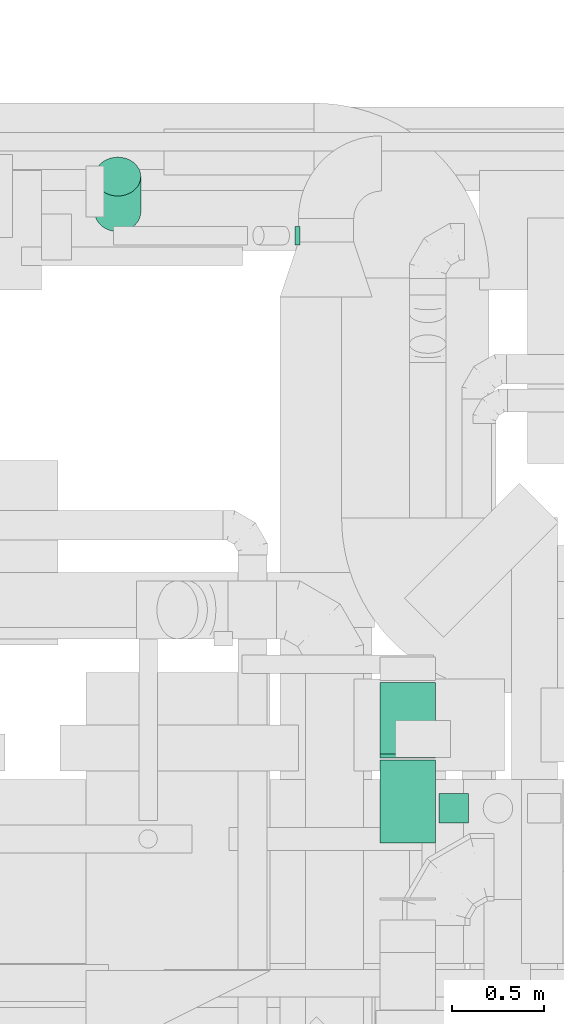
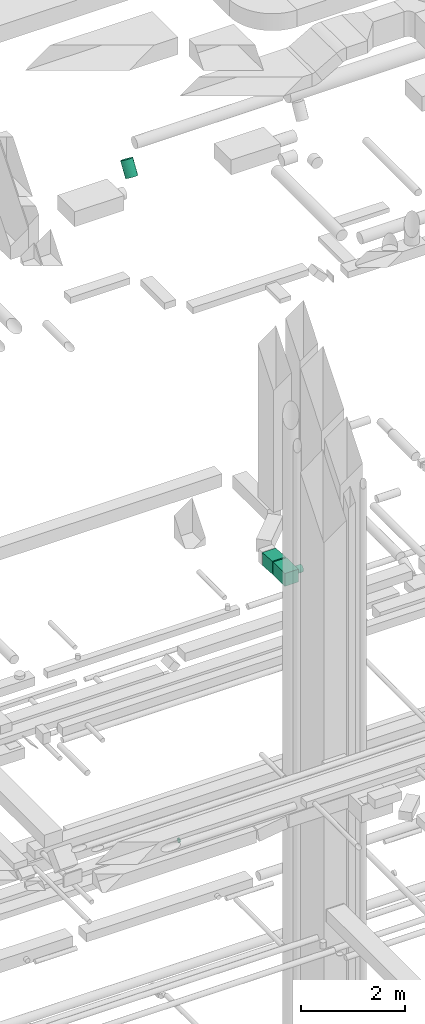
# One storey, part 278 of 337: 5 flow segments.
"""IFC2X3 building model written with IfcOpenShell, lengths in millimetres."""

from ifc_helpers import new_model, entity, si_unit, converted_unit, derived_unit, direction, frame, frame_2d, origin, origin_2d_with_axis, place, context, subcontext, project, spatial, rectangle, circle, extrude, type_object, element, save


model = new_model("IFC2X3")

# Units and contexts
model_context = context("Model", 3, precision=0.01, world=origin(), true_north=direction((6.12303176911189e-17, 1.0)))
body_context = subcontext(model_context, "Body", "Model", "MODEL_VIEW")
ifc_project = project(units=[si_unit("LENGTHUNIT", "METRE", prefix="MILLI"), si_unit("AREAUNIT", "SQUARE_METRE"), si_unit("VOLUMEUNIT", "CUBIC_METRE"), converted_unit("PLANEANGLEUNIT", "DEGREE", entity("IfcRatioMeasure", 0.0174532925199433), si_unit("PLANEANGLEUNIT", "RADIAN"), dimensions=[0, 0, 0, 0, 0, 0, 0]), si_unit("MASSUNIT", "GRAM", prefix="KILO"), derived_unit("MASSDENSITYUNIT", [(si_unit("MASSUNIT", "GRAM", prefix="KILO"), 1), (si_unit("LENGTHUNIT", "METRE"), -3)]), derived_unit("MOMENTOFINERTIAUNIT", [(si_unit("LENGTHUNIT", "METRE"), 4)]), si_unit("TIMEUNIT", "SECOND"), si_unit("FREQUENCYUNIT", "HERTZ"), si_unit("THERMODYNAMICTEMPERATUREUNIT", "DEGREE_CELSIUS"), derived_unit("THERMALTRANSMITTANCEUNIT", [(si_unit("MASSUNIT", "GRAM", prefix="KILO"), 1), (si_unit("THERMODYNAMICTEMPERATUREUNIT", "KELVIN"), -1), (si_unit("TIMEUNIT", "SECOND"), -3)]), derived_unit("VOLUMETRICFLOWRATEUNIT", [(si_unit("LENGTHUNIT", "METRE"), 3), (si_unit("TIMEUNIT", "SECOND"), -1)]), derived_unit("MASSFLOWRATEUNIT", [(si_unit("MASSUNIT", "GRAM", prefix="KILO"), 1), (si_unit("TIMEUNIT", "SECOND"), -1)]), derived_unit("ROTATIONALFREQUENCYUNIT", [(si_unit("TIMEUNIT", "SECOND"), -1)]), si_unit("ELECTRICCURRENTUNIT", "AMPERE"), si_unit("ELECTRICVOLTAGEUNIT", "VOLT"), si_unit("POWERUNIT", "WATT"), si_unit("FORCEUNIT", "NEWTON", prefix="KILO"), si_unit("ILLUMINANCEUNIT", "LUX"), si_unit("LUMINOUSFLUXUNIT", "LUMEN"), si_unit("LUMINOUSINTENSITYUNIT", "CANDELA"), derived_unit("USERDEFINED", [(si_unit("MASSUNIT", "GRAM", prefix="KILO"), -1), (si_unit("LENGTHUNIT", "METRE"), -2), (si_unit("TIMEUNIT", "SECOND"), 3), (si_unit("LUMINOUSFLUXUNIT", "LUMEN"), 1)]), derived_unit("LINEARVELOCITYUNIT", [(si_unit("LENGTHUNIT", "METRE"), 1), (si_unit("TIMEUNIT", "SECOND"), -1)]), si_unit("PRESSUREUNIT", "PASCAL"), derived_unit("USERDEFINED", [(si_unit("LENGTHUNIT", "METRE"), -2), (si_unit("MASSUNIT", "GRAM", prefix="KILO"), 1), (si_unit("TIMEUNIT", "SECOND"), -2)]), derived_unit("LINEARFORCEUNIT", [(si_unit("MASSUNIT", "GRAM", prefix="KILO"), 1), (si_unit("LENGTHUNIT", "METRE"), 1), (si_unit("TIMEUNIT", "SECOND"), -2), (si_unit("LENGTHUNIT", "METRE"), -1)]), derived_unit("PLANARFORCEUNIT", [(si_unit("MASSUNIT", "GRAM", prefix="KILO"), 1), (si_unit("LENGTHUNIT", "METRE"), 1), (si_unit("TIMEUNIT", "SECOND"), -2), (si_unit("LENGTHUNIT", "METRE"), -2)])], contexts=[model_context])

# Site, building, storey
site_placement = place(None, origin())
site = spatial("IfcSite", under=ifc_project, at=site_placement, CompositionType="ELEMENT")
building_placement = place(site_placement, origin())
building = spatial("IfcBuilding", under=site, at=building_placement, CompositionType="ELEMENT")
storey_placement = place(building_placement, origin())
storey = spatial("IfcBuildingStorey", under=building, at=storey_placement, CompositionType="ELEMENT", Elevation=0.0)

# Flow segments
duct_segment_type_1 = type_object("IfcDuctSegmentType", PredefinedType="NOTDEFINED")
flow_segment_1_placement = place(storey_placement, frame((46619.03, 16570.21, 19021.2)))
element("IfcFlowSegment", 1, at=flow_segment_1_placement, inside=storey, type_object=duct_segment_type_1, context=body_context, shape_type="SweptSolid", body=[
    extrude(rectangle(XDim=300.000000000002, YDim=389.27575588517, at=frame_2d((0.0, 0.0), x_axis=(0.0, 1.0))), frame((0.0, 205.06, 163.8), z_axis=(1.0, 0.0, 0.0), x_axis=(0.0, -0.997334975567425, 0.0729585259577274)), (0.0, 0.0, 1.0), 300.000000000001),
])
flow_segment_2_placement = place(storey_placement, frame((46619.03, 16110.23, 19050.0)))
element("IfcFlowSegment", 2, at=flow_segment_2_placement, inside=storey, type_object=duct_segment_type_1, context=body_context, shape_type="SweptSolid", body=[
    extrude(rectangle(XDim=449.041618929892, YDim=300.000000000001, at=origin_2d_with_axis()), frame((150.0, 224.52, 0.0), z_axis=(0.0, 0.0, 1.0), x_axis=(0.0, -1.0, 0.0)), (0.0, 0.0, 1.0), 300.000000000001),
])
duct_segment_type_2 = type_object("IfcDuctSegmentType", PredefinedType="NOTDEFINED")
flow_segment_3_placement = place(storey_placement, frame((46157.39, 19353.19, 11203.97)))
element("IfcFlowSegment", 3, at=flow_segment_3_placement, inside=storey, type_object=duct_segment_type_2, context=body_context, shape_type="SweptSolid", body=[
    extrude(circle(Radius=50.0, at=origin_2d_with_axis()), frame((0.0, 51.6, 51.6), z_axis=(1.0, 0.0, 0.0), x_axis=(0.0, -1.0, 0.0)), (0.0, 0.0, 1.0), 26.6347957254866),
])
flow_segment_4_placement = place(storey_placement, frame((46939.03, 16216.25, 19118.4)))
element("IfcFlowSegment", 4, at=flow_segment_4_placement, inside=storey, type_object=duct_segment_type_2, context=body_context, shape_type="SweptSolid", body=[
    extrude(circle(Radius=80.0, at=origin_2d_with_axis()), frame((0.0, 81.6, 81.6), z_axis=(1.0, 0.0, 0.0), x_axis=(0.0, 1.0, 0.0)), (0.0, 0.0, 1.0), 159.062500000026),
])
flow_segment_5_placement = place(storey_placement, frame((45069.11, 19424.89, 27017.25)))
element("IfcFlowSegment", 5, at=flow_segment_5_placement, inside=storey, type_object=duct_segment_type_2, context=body_context, shape_type="SweptSolid", body=[
    extrude(circle(Radius=125.0, at=origin_2d_with_axis()), frame((126.6, 107.06, 68.69), z_axis=(0.0, 0.536753132175991, 0.843739340732233), x_axis=(-1.0, 0.0, 0.0)), (0.0, 0.0, 1.0), 359.270114595904),
])

save(model, "model.ifc")
